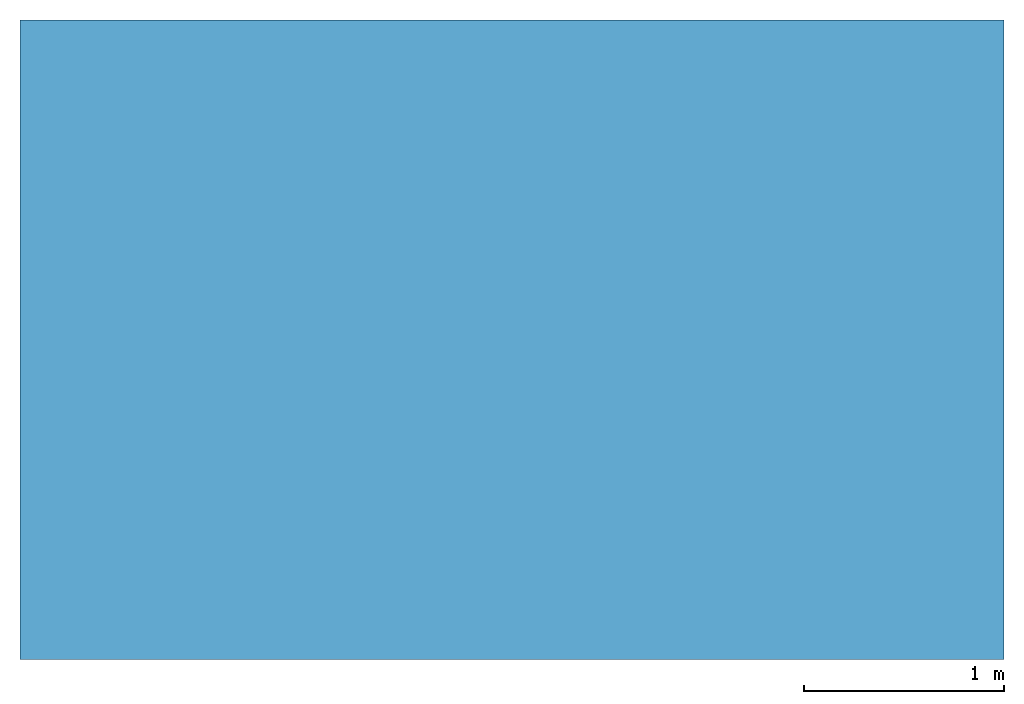
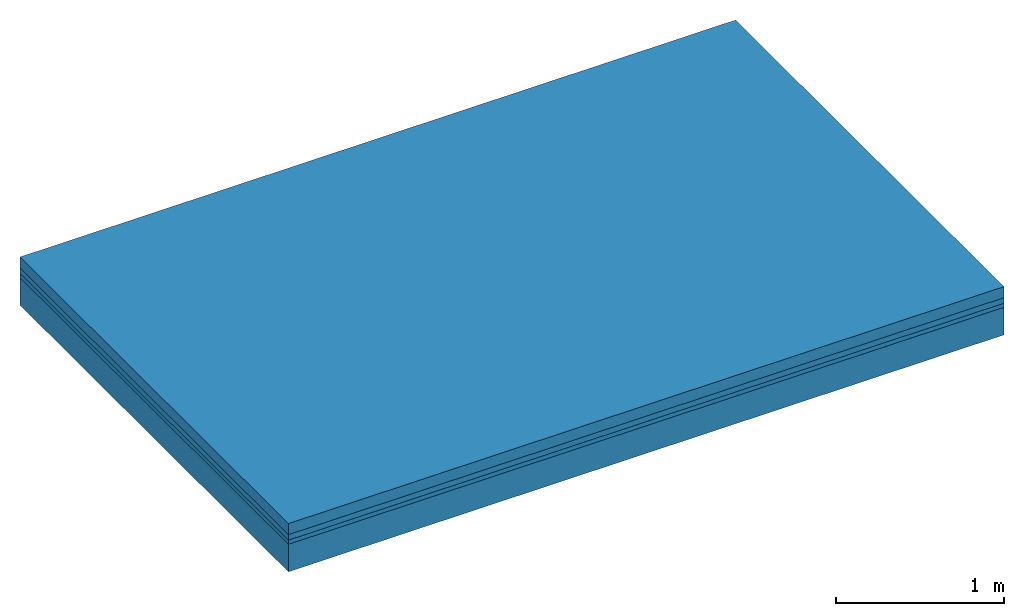
# One storey: 4 building element parts, 1 element without a shape of its own.
"""IFC2X3 building model written with IfcOpenShell, lengths in metres."""

from ifc_helpers import new_model, entity, si_unit, converted_unit, derived_unit, money_unit, direction, frame, origin_with_axes, place, context, subcontext, project, spatial, polyline, outline, extrude, material, type_object, element, aggregate, save


model = new_model("IFC2X3")

# Units and contexts
model_context = context("Model", 3, precision=1e-05, world=origin_with_axes(), true_north=direction((0.309016994375, 0.951056516295)))
body_context = subcontext(model_context, "Body", "Model", "MODEL_VIEW")
ifc_project = project(units=[si_unit("LENGTHUNIT", "METRE"), si_unit("AREAUNIT", "SQUARE_METRE"), si_unit("VOLUMEUNIT", "CUBIC_METRE"), converted_unit("PLANEANGLEUNIT", "DEGREE", entity("IfcPlaneAngleMeasure", 0.0174532925199), si_unit("PLANEANGLEUNIT", "RADIAN"), dimensions=[0, 0, 0, 0, 0, 0, 0]), si_unit("SOLIDANGLEUNIT", "STERADIAN"), money_unit("EUR"), si_unit("TIMEUNIT", "SECOND"), si_unit("MASSUNIT", "GRAM", prefix="KILO"), si_unit("THERMODYNAMICTEMPERATUREUNIT", "DEGREE_CELSIUS"), si_unit("LUMINOUSINTENSITYUNIT", "LUMEN"), si_unit("ENERGYUNIT", "JOULE", prefix="MEGA"), derived_unit("THERMALCONDUCTANCEUNIT", [(si_unit("POWERUNIT", "WATT"), 1), (si_unit("LENGTHUNIT", "METRE"), -1), (si_unit("THERMODYNAMICTEMPERATUREUNIT", "KELVIN"), -1)]), derived_unit("SPECIFICHEATCAPACITYUNIT", [(si_unit("ENERGYUNIT", "JOULE"), 1), (si_unit("MASSUNIT", "GRAM", prefix="KILO"), -1), (si_unit("THERMODYNAMICTEMPERATUREUNIT", "KELVIN"), -1)]), derived_unit("MASSDENSITYUNIT", [(si_unit("MASSUNIT", "GRAM", prefix="KILO"), 1), (si_unit("VOLUMEUNIT", "CUBIC_METRE"), -1)])], contexts=[model_context])

# Site, building, storey
site_placement = place(None, origin_with_axes())
site = spatial("IfcSite", under=ifc_project, at=site_placement, CompositionType="ELEMENT")
building_placement = place(site_placement, origin_with_axes())
building = spatial("IfcBuilding", under=site, at=building_placement, CompositionType="ELEMENT")
storey_placement = place(building_placement, origin_with_axes())
storey = spatial("IfcBuildingStorey", under=building, at=storey_placement, Name="Erdgeschoss", CompositionType="ELEMENT", Elevation=0.0)

# Slab, building element parts
slab_type = type_object("IfcSlabType", Name="302_Decke allgemein (LOD200) 350", PredefinedType="FLOOR")
slab_placement = place(storey_placement, frame((3.43012829992, 2.40402879337, -0.15), z_axis=(0.0, 0.0, 1.0), x_axis=(1.0, 0.0, 0.0)))
slab = element("IfcSlab", 1, at=slab_placement, inside=storey, type_object=slab_type, PredefinedType="FLOOR")
ifc_material_1 = material(Name="Beton, Stahlbeton Decke")
building_element_part_1_placement = place(slab_placement, origin_with_axes())
building_element_part_1 = element("IfcBuildingElementPart", 2, at=building_element_part_1_placement, material=ifc_material_1, Name="Beton, Stahlbeton Decke", context=body_context, shape_type="SweptSolid", body=[
    extrude(outline(polyline([(0.0, 0.0), (4.91326862204, 0.0), (4.91326862204, 3.19237758183), (0.0, 3.19237758183), (0.0, 0.0)])), frame((0.0, 0.0, -0.2), z_axis=(0.0, 0.0, 1.0), x_axis=(1.0, 0.0, 0.0)), (0.0, 0.0, 1.0), 0.2),
])
ifc_material_2 = material(Name="Boden, Sand")
building_element_part_2_placement = place(slab_placement, origin_with_axes())
building_element_part_2 = element("IfcBuildingElementPart", 3, at=building_element_part_2_placement, material=ifc_material_2, Name="Boden, Sand", context=body_context, shape_type="SweptSolid", body=[
    extrude(outline(polyline([(0.0, 0.0), (4.91326862204, 0.0), (4.91326862204, 3.19237758183), (0.0, 3.19237758183), (0.0, 0.0)])), origin_with_axes(), (0.0, 0.0, 1.0), 0.03),
])
ifc_material_3 = material()
building_element_part_3_placement = place(slab_placement, origin_with_axes())
building_element_part_3 = element("IfcBuildingElementPart", 4, at=building_element_part_3_placement, material=ifc_material_3, context=body_context, shape_type="SweptSolid", body=[
    extrude(outline(polyline([(0.0, 0.0), (4.91326862204, 0.0), (4.91326862204, 3.19237758183), (0.0, 3.19237758183), (0.0, 0.0)])), frame((0.0, 0.0, 0.03), z_axis=(0.0, 0.0, 1.0), x_axis=(1.0, 0.0, 0.0)), (0.0, 0.0, 1.0), 0.04),
])
ifc_material_4 = material(Name="Estrich")
building_element_part_4_placement = place(slab_placement, origin_with_axes())
building_element_part_4 = element("IfcBuildingElementPart", 5, at=building_element_part_4_placement, material=ifc_material_4, Name="Estrich", context=body_context, shape_type="SweptSolid", body=[
    extrude(outline(polyline([(0.0, 0.0), (4.91326862204, 0.0), (4.91326862204, 3.19237758183), (0.0, 3.19237758183), (0.0, 0.0)])), frame((0.0, 0.0, 0.07), z_axis=(0.0, 0.0, 1.0), x_axis=(1.0, 0.0, 0.0)), (0.0, 0.0, 1.0), 0.08),
])
aggregate(slab, [building_element_part_1, building_element_part_2, building_element_part_3, building_element_part_4])

save(model, "model.ifc")
